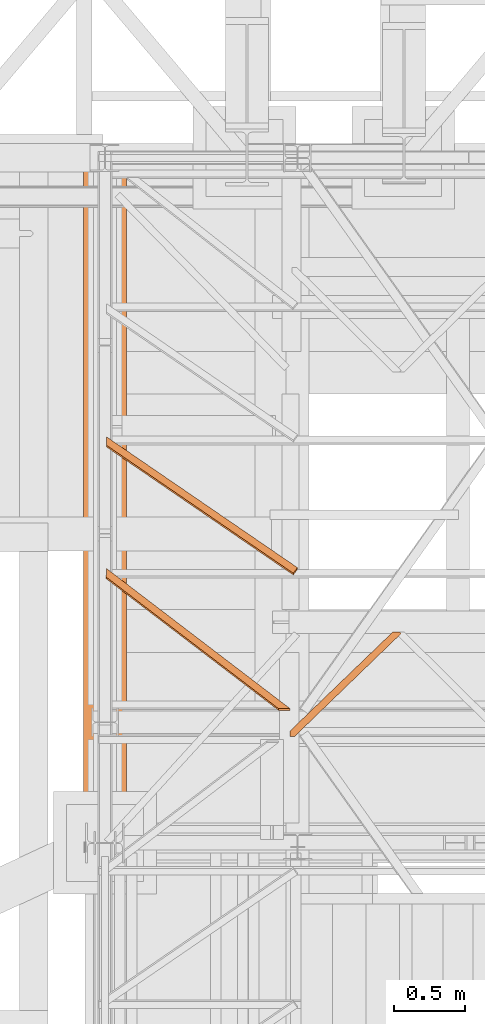
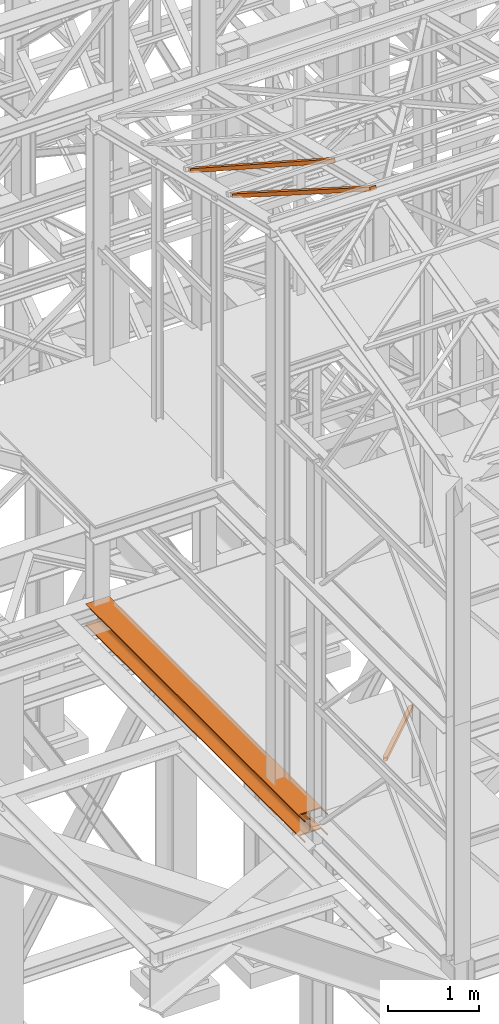
# One storey, part 27 of 208: 4 proxies.
"""IFC2X3 building model written with IfcOpenShell, lengths in millimetres."""

from ifc_helpers import new_model, entity, si_unit, converted_unit, frame, origin, origin_with_axes, place, context, subcontext, project, spatial, faceted_brep, element, save


model = new_model("IFC2X3")

# Units and contexts
model_context = context("Model", 3, precision=1e-05, world=origin())
plan_context = context("Plan", 3, precision=1e-05, world=origin())
body_context = subcontext(model_context, "Body", "Model", "MODEL_VIEW")
ifc_project = project(units=[si_unit("LENGTHUNIT", "METRE", prefix="MILLI"), converted_unit("PLANEANGLEUNIT", "DEGREE", entity("IfcPlaneAngleMeasure", 0.0174532925199433), si_unit("PLANEANGLEUNIT", "RADIAN"), dimensions=[0, 0, 0, 0, 0, 0, 0]), si_unit("AREAUNIT", "SQUARE_METRE"), si_unit("VOLUMEUNIT", "CUBIC_METRE")], contexts=[model_context, plan_context])

# Building, storey
building_placement = place(None, origin())
building = spatial("IfcBuilding", under=ifc_project, at=building_placement, CompositionType="COMPLEX")
storey_placement = place(building_placement, origin_with_axes())
storey = spatial("IfcBuildingStorey", under=building, at=storey_placement, Name="Geschoss", CompositionType="ELEMENT")

# Proxies
proxy_1_placement = place(storey_placement, frame((2493.538204317862, -21317.27439027057, 5124.989999999998), z_axis=(0.0, 0.0, 1.0), x_axis=(1.0, 0.0, 0.0)))
element("IfcBuildingElementProxy", 1, at=proxy_1_placement, inside=storey, context=body_context, shape_type="Brep", body=[
    faceted_brep([(722.7511509365713, 733.210000142677, 50.01000000000022), (0.01000000000021828, 37.12981500374735, 50.01000000000022), (0.01000000000021828, 37.12981500374735, 0.01000000000021828), (722.7511509365713, 733.210000142677, 0.01000000000021828), (722.7511509365713, 733.210000142677, 0.01000000000021828), (0.01000000000021828, 37.12981500374735, 0.01000000000021828), (0.01000000000112777, 0.00999999999839929, 0.01000000000021828), (33.18012058976092, 0.00999999999839929, 0.009999999999308784), (780.9982888236364, 722.3501135925508, 0.01000000000021828), (766.4063343387788, 733.210000142677, 0.01000000000021828), (780.9982888236364, 722.3501135925508, 0.01000000000021828), (33.18012058976092, 0.00999999999839929, 0.009999999999308784), (33.18012058976092, 0.00999999999839929, 50.00999999999931), (780.9982888236364, 722.3501135925508, 50.01000000000022), (780.9982888236364, 722.3501135925508, 50.01000000000022), (33.18012058976092, 0.00999999999839929, 50.00999999999931), (0.01000000000203727, 0.00999999999839929, 50.01000000000022), (0.01000000000021828, 37.12981500374735, 50.01000000000022), (722.7511509365713, 733.210000142677, 50.01000000000022), (766.4063343387788, 733.210000142677, 50.01000000000022), (766.4063343387788, 733.210000142677, 0.01000000000021828), (780.9982888236364, 722.3501135925508, 0.01000000000021828), (780.9982888236364, 722.3501135925508, 50.01000000000022), (766.4063343387788, 733.210000142677, 50.01000000000022), (766.4063343387788, 733.210000142677, 46.01000000000022), (777.7894357355754, 724.7382638933559, 46.01000000000022), (777.7894357355754, 724.7382638933559, 4.010000000000218), (766.4063343387788, 733.210000142677, 4.010000000000218), (728.2405771232097, 733.210000142677, 4.010000000000218), (0.01000000000203727, 31.38144639979873, 4.010000000000218), (0.01000000000203727, 31.38144639979873, 46.01000000000022), (728.2405771232097, 733.210000142677, 46.01000000000022), (766.4063343387788, 733.210000142677, 4.010000000000218), (777.7894357355754, 724.7382638933559, 4.010000000000218), (27.69069440312251, 0.00999999999839929, 4.010000000000218), (0.01000000000203727, 0.00999999999839929, 4.010000000000218), (0.01000000000203727, 31.38144639979873, 4.010000000000218), (728.2405771232097, 733.210000142677, 4.010000000000218), (777.7894357355754, 724.7382638933559, 4.010000000000218), (777.7894357355754, 724.7382638933559, 46.01000000000022), (27.69069440312251, 0.00999999999839929, 46.01000000000022), (27.69069440312251, 0.00999999999839929, 4.010000000000218), (777.7894357355754, 724.7382638933559, 46.01000000000022), (766.4063343387788, 733.210000142677, 46.01000000000022), (728.2405771232097, 733.210000142677, 46.01000000000022), (0.01000000000203727, 31.38144639979873, 46.01000000000022), (0.01000000000112777, 0.00999999999839929, 46.01000000000022), (27.69069440312251, 0.00999999999839929, 46.01000000000022), (0.01000000000203727, 0.00999999999839929, 4.010000000000218), (27.69069440312251, 0.00999999999839929, 4.010000000000218), (27.69069440312251, 0.00999999999839929, 46.01000000000022), (0.01000000000112777, 0.00999999999839929, 46.01000000000022), (0.01000000000203727, 0.00999999999839929, 50.01000000000022), (33.18012058976092, 0.00999999999839929, 50.00999999999931), (33.18012058976092, 0.00999999999839929, 0.009999999999308784), (0.01000000000112777, 0.00999999999839929, 0.01000000000021828), (0.01000000000021828, 37.12981500374735, 50.01000000000022), (0.01000000000203727, 0.00999999999839929, 50.01000000000022), (0.01000000000112777, 0.00999999999839929, 46.01000000000022), (0.01000000000203727, 31.38144639979873, 46.01000000000022), (0.01000000000203727, 31.38144639979873, 4.010000000000218), (0.01000000000203727, 0.00999999999839929, 4.010000000000218), (0.01000000000112777, 0.00999999999839929, 0.01000000000021828), (0.01000000000021828, 37.12981500374735, 0.01000000000021828), (722.7511509365713, 733.210000142677, 0.01000000000021828), (766.4063343387788, 733.210000142677, 0.01000000000021828), (766.4063343387788, 733.210000142677, 4.010000000000218), (728.2405771232097, 733.210000142677, 4.010000000000218), (728.2405771232097, 733.210000142677, 46.01000000000022), (766.4063343387788, 733.210000142677, 46.01000000000022), (766.4063343387788, 733.210000142677, 50.01000000000022), (722.7511509365713, 733.210000142677, 50.01000000000022)], [[[0, 1, 2, 3]], [[4, 5, 6, 7, 8, 9]], [[10, 11, 12, 13]], [[14, 15, 16, 17, 18, 19]], [[20, 21, 22, 23, 24, 25, 26, 27]], [[28, 29, 30, 31]], [[32, 33, 34, 35, 36, 37]], [[38, 39, 40, 41]], [[42, 43, 44, 45, 46, 47]], [[48, 49, 50, 51, 52, 53, 54, 55]], [[56, 57, 58, 59, 60, 61, 62, 63]], [[64, 65, 66, 67, 68, 69, 70, 71]]], orient=[[False], [False], [False], [False], [False], [False], [False], [False], [False], [False], [False], [False]]),
])
proxy_2_placement = place(storey_placement, frame((1209.754965757054, -20185.54963276443, 12214.24717333412), z_axis=(0.0, 0.0, 1.0), x_axis=(1.0, 0.0, 0.0)))
element("IfcBuildingElementProxy", 2, at=proxy_2_placement, inside=storey, context=body_context, shape_type="Brep", body=[
    faceted_brep([(1308.5389233782, 0.00999999999839929, 232.0521250666225), (1308.5389233782, 11.80406569683328, 280.6412186405796), (1337.349720073477, 51.51581022395476, 271.0019582749592), (1337.349720073477, 39.72174452711988, 222.4128647010039), (0.009999999999990905, 896.5242864318316, 14.44056628674844), (0.009999999999990905, 908.3183521286664, 63.02965986070558), (1308.5389233782, 11.80406569683328, 280.6412186405796), (1308.5389233782, 0.00999999999839929, 232.0521250666225), (0.009999999999990905, 955.9752131652676, 0.01000000000021828), (0.009999999999990905, 896.5242864318316, 14.44056628674844), (1308.5389233782, 0.00999999999839929, 232.0521250666225), (1337.349720073477, 39.72174452711988, 222.4128647010039), (0.009999999999990905, 967.7692788621025, 48.59909357395554), (0.009999999999990905, 955.9752131652676, 0.01000000000021828), (1337.349720073477, 39.72174452711988, 222.4128647010039), (1337.349720073477, 51.51581022395476, 271.0019582749592), (0.009999999999990905, 908.3183521286664, 63.02965986070558), (0.009999999999990905, 967.7692788621025, 48.59909357395554), (1337.349720073477, 51.51581022395476, 271.0019582749592), (1308.5389233782, 11.80406569683328, 280.6412186405796), (0.009999999999990905, 896.5242864318316, 14.44056628674844), (0.009999999999990905, 955.9752131652676, 0.01000000000021828), (0.009999999999990905, 967.7692788621025, 48.59909357395554), (0.009999999999990905, 908.3183521286664, 63.02965986070558)], [[[0, 1, 2, 3]], [[4, 5, 6, 7]], [[8, 9, 10, 11]], [[12, 13, 14, 15]], [[16, 17, 18, 19]], [[20, 21, 22, 23]]], orient=[[False], [False], [False], [False], [False], [False]]),
])
proxy_3_placement = place(storey_placement, frame((1048.164817752956, -22062.57438972183, 4994.990005364416), z_axis=(0.0, 0.0, 1.0), x_axis=(1.0, 0.0, 0.0)))
element("IfcBuildingElementProxy", 3, at=proxy_3_placement, inside=storey, context=body_context, shape_type="Brep", body=[
    faceted_brep([(300.01, 0.00999999999839929, 290.0100000000002), (300.0100000000009, 4805.080528512528, 290.0100000000002), (300.0100000000009, 4805.080528512528, 276.0100000000002), (300.01, 0.00999999999839929, 276.0100000000002), (300.01, 0.00999999999839929, 276.0100000000002), (300.0100000000009, 4805.080528512528, 276.0100000000002), (181.2600000000009, 4805.080528512528, 276.0100000000002), (181.26, 140.0099999999984, 276.0100000000002), (285.0100063934713, 140.0099999999984, 276.0100000000002), (285.0100063934713, 0.00999999999839929, 276.0100000000002), (181.26, 140.0099999999984, 276.0100000000002), (181.2600000000009, 4805.080528512528, 276.0100000000002), (172.9165694541396, 4805.080528512528, 274.6884339422595), (172.9165694541387, 140.0099999999984, 274.6884339422595), (172.9165694541387, 140.0099999999984, 274.6884339422595), (172.9165694541396, 4805.080528512528, 274.6884339422595), (165.3898249341989, 4805.080528512528, 270.8534254634033), (165.389824934198, 140.0099999999984, 270.8534254634024), (165.389824934198, 140.0099999999984, 270.8534254634024), (165.3898249341989, 4805.080528512528, 270.8534254634033), (159.4165745365979, 4805.080528512528, 264.8801750658022), (159.416574536597, 140.0099999999984, 264.8801750658022), (159.416574536597, 140.0099999999984, 264.8801750658022), (159.4165745365979, 4805.080528512528, 264.8801750658022), (155.5815660577398, 4805.080528512528, 257.3534305458616), (155.5815660577389, 140.0099999999984, 257.3534305458607), (155.5815660577389, 140.0099999999984, 257.3534305458607), (155.5815660577398, 4805.080528512528, 257.3534305458616), (154.2600000000009, 4805.080528512528, 249.0100000000002), (154.26, 140.0099999999984, 249.0100000000002), (154.26, 140.0099999999984, 249.0100000000002), (154.2600000000009, 4805.080528512528, 249.0100000000002), (154.2600000000009, 4805.080528512528, 41.01000000000022), (154.26, 140.0099999999984, 41.01000000000022), (154.26, 140.0099999999984, 41.01000000000022), (154.2600000000009, 4805.080528512528, 41.01000000000022), (155.5815660577398, 4805.080528512528, 32.6665694541407), (155.5815660577389, 140.0099999999984, 32.66656945413979), (155.5815660577389, 140.0099999999984, 32.66656945413979), (155.5815660577398, 4805.080528512528, 32.6665694541407), (159.4165745365979, 4805.080528512528, 25.13982493419917), (159.416574536597, 140.0099999999984, 25.13982493419826), (159.416574536597, 140.0099999999984, 25.13982493419826), (159.4165745365979, 4805.080528512528, 25.13982493419917), (165.3898249341989, 4805.080528512528, 19.166574536599), (165.389824934198, 140.0099999999984, 19.16657453659809), (165.389824934198, 140.0099999999984, 19.16657453659809), (165.3898249341989, 4805.080528512528, 19.166574536599), (172.9165694541396, 4805.080528512528, 15.33156605774093), (172.9165694541387, 140.0099999999984, 15.33156605774093), (172.9165694541387, 140.0099999999984, 15.33156605774093), (172.9165694541396, 4805.080528512528, 15.33156605774093), (181.2600000000009, 4805.080528512528, 14.01000000000022), (181.26, 140.0099999999984, 14.01000000000022), (181.26, 140.0099999999984, 14.01000000000022), (181.2600000000009, 4805.080528512528, 14.01000000000022), (300.0100000000009, 4805.080528512528, 14.01000000000022), (300.01, 0.00999999999839929, 14.01000000000022), (285.0100063934713, 0.00999999999839929, 14.01000000000022), (285.0100063934713, 140.0099999999984, 14.01000000000022), (300.01, 0.00999999999839929, 14.01000000000022), (300.0100000000009, 4805.080528512528, 14.01000000000022), (300.0100000000009, 4805.080528512528, 0.01000000000021828), (300.01, 0.00999999999839929, 0.01000000000021828), (300.01, 0.00999999999839929, 0.01000000000021828), (300.0100000000009, 4805.080528512528, 0.01000000000021828), (0.0100000000009004, 4805.080528512528, 0.01000000000021828), (0.009999999999990905, 0.00999999999839929, 0.01000000000021828), (15.0099956646352, 0.00999999999839929, 0.01000000000021828), (15.0099956646352, 140.0099999999984, 0.01000000000021828), (285.0100063934713, 140.0099999999984, 0.01000000000021828), (285.0100063934713, 0.00999999999839929, 0.01000000000021828), (0.009999999999990905, 0.00999999999839929, 0.01000000000021828), (0.0100000000009004, 4805.080528512528, 0.01000000000021828), (0.0100000000009004, 4805.080528512528, 14.01000000000022), (0.009999999999990905, 0.00999999999839929, 14.01000000000022), (0.009999999999990905, 0.00999999999839929, 14.01000000000022), (0.0100000000009004, 4805.080528512528, 14.01000000000022), (118.7600000000009, 4805.080528512528, 14.01000000000022), (118.76, 140.0099999999984, 14.01000000000022), (15.0099956646352, 140.0099999999984, 14.01000000000022), (15.0099956646352, 0.00999999999839929, 14.01000000000022), (118.76, 140.0099999999984, 14.01000000000022), (118.7600000000009, 4805.080528512528, 14.01000000000022), (127.1034305458604, 4805.080528512528, 15.33156605774093), (127.1034305458595, 140.0099999999984, 15.33156605774093), (127.1034305458595, 140.0099999999984, 15.33156605774093), (127.1034305458604, 4805.080528512528, 15.33156605774093), (134.630175065801, 4805.080528512528, 19.166574536599), (134.6301750658001, 140.0099999999984, 19.16657453659809), (134.6301750658001, 140.0099999999984, 19.16657453659809), (134.630175065801, 4805.080528512528, 19.166574536599), (140.6034254634021, 4805.080528512528, 25.13982493419917), (140.6034254634012, 140.0099999999984, 25.13982493419826), (140.6034254634012, 140.0099999999984, 25.13982493419826), (140.6034254634021, 4805.080528512528, 25.13982493419917), (144.4384339422602, 4805.080528512528, 32.6665694541407), (144.4384339422593, 140.0099999999984, 32.66656945413979), (144.4384339422593, 140.0099999999984, 32.66656945413979), (144.4384339422602, 4805.080528512528, 32.6665694541407), (145.7600000000009, 4805.080528512528, 41.01000000000022), (145.76, 140.0099999999984, 41.01000000000022), (145.76, 140.0099999999984, 41.01000000000022), (145.7600000000009, 4805.080528512528, 41.01000000000022), (145.7600000000009, 4805.080528512528, 249.0100000000002), (145.76, 140.0099999999984, 249.0100000000002), (145.76, 140.0099999999984, 249.0100000000002), (145.7600000000009, 4805.080528512528, 249.0100000000002), (144.4384339422602, 4805.080528512528, 257.3534305458616), (144.4384339422593, 140.0099999999984, 257.3534305458607), (144.4384339422593, 140.0099999999984, 257.3534305458607), (144.4384339422602, 4805.080528512528, 257.3534305458616), (140.6034254634021, 4805.080528512528, 264.8801750658022), (140.6034254634012, 140.0099999999984, 264.8801750658022), (140.6034254634012, 140.0099999999984, 264.8801750658022), (140.6034254634021, 4805.080528512528, 264.8801750658022), (134.630175065801, 4805.080528512528, 270.8534254634033), (134.6301750658001, 140.0099999999984, 270.8534254634024), (134.6301750658001, 140.0099999999984, 270.8534254634024), (134.630175065801, 4805.080528512528, 270.8534254634033), (127.1034305458604, 4805.080528512528, 274.6884339422595), (127.1034305458595, 140.0099999999984, 274.6884339422595), (127.1034305458595, 140.0099999999984, 274.6884339422595), (127.1034305458604, 4805.080528512528, 274.6884339422595), (118.7600000000009, 4805.080528512528, 276.0100000000002), (118.76, 140.0099999999984, 276.0100000000002), (118.76, 140.0099999999984, 276.0100000000002), (118.7600000000009, 4805.080528512528, 276.0100000000002), (0.0100000000009004, 4805.080528512528, 276.0100000000002), (0.009999999999990905, 0.00999999999839929, 276.0100000000002), (15.0099956646352, 0.00999999999839929, 276.0100000000002), (15.0099956646352, 140.0099999999984, 276.0100000000002), (0.009999999999990905, 0.00999999999839929, 276.0100000000002), (0.0100000000009004, 4805.080528512528, 276.0100000000002), (0.0100000000009004, 4805.080528512528, 290.0100000000002), (0.009999999999990905, 0.00999999999839929, 290.0100000000002), (0.009999999999990905, 0.00999999999839929, 290.0100000000002), (0.0100000000009004, 4805.080528512528, 290.0100000000002), (300.0100000000009, 4805.080528512528, 290.0100000000002), (300.01, 0.00999999999839929, 290.0100000000002), (285.0100063934704, 0.00999999999839929, 290.0100000000002), (285.0100063934704, 140.0099999999984, 290.0100000000002), (15.0099956646352, 140.0099999999984, 290.0100000000002), (15.0099956646352, 0.00999999999839929, 290.0100000000002), (300.01, 0.00999999999839929, 290.0100000000002), (300.01, 0.00999999999839929, 276.0100000000002), (285.0100063934713, 0.00999999999839929, 276.0100000000002), (285.0100063934704, 0.00999999999839929, 290.0100000000002), (15.0099956646352, 0.00999999999839929, 14.01000000000022), (15.0099956646352, 0.00999999999839929, 0.01000000000021828), (0.009999999999990905, 0.00999999999839929, 0.01000000000021828), (0.009999999999990905, 0.00999999999839929, 14.01000000000022), (15.0099956646352, 0.00999999999839929, 276.0100000000002), (0.009999999999990905, 0.00999999999839929, 276.0100000000002), (0.009999999999990905, 0.00999999999839929, 290.0100000000002), (15.0099956646352, 0.00999999999839929, 290.0100000000002), (285.0100063934713, 0.00999999999839929, 0.01000000000021828), (285.0100063934713, 0.00999999999839929, 14.01000000000022), (300.01, 0.00999999999839929, 14.01000000000022), (300.01, 0.00999999999839929, 0.01000000000021828), (300.0100000000009, 4805.080528512528, 290.0100000000002), (0.0100000000009004, 4805.080528512528, 290.0100000000002), (0.0100000000009004, 4805.080528512528, 276.0100000000002), (118.7600000000009, 4805.080528512528, 276.0100000000002), (127.1034305458604, 4805.080528512528, 274.6884339422595), (134.630175065801, 4805.080528512528, 270.8534254634033), (140.6034254634021, 4805.080528512528, 264.8801750658022), (144.4384339422602, 4805.080528512528, 257.3534305458616), (145.7600000000009, 4805.080528512528, 249.0100000000002), (145.7600000000009, 4805.080528512528, 41.01000000000022), (144.4384339422602, 4805.080528512528, 32.6665694541407), (140.6034254634021, 4805.080528512528, 25.13982493419917), (134.630175065801, 4805.080528512528, 19.166574536599), (127.1034305458604, 4805.080528512528, 15.33156605774093), (118.7600000000009, 4805.080528512528, 14.01000000000022), (0.0100000000009004, 4805.080528512528, 14.01000000000022), (0.0100000000009004, 4805.080528512528, 0.01000000000021828), (300.0100000000009, 4805.080528512528, 0.01000000000021828), (300.0100000000009, 4805.080528512528, 14.01000000000022), (181.2600000000009, 4805.080528512528, 14.01000000000022), (172.9165694541396, 4805.080528512528, 15.33156605774093), (165.3898249341989, 4805.080528512528, 19.166574536599), (159.4165745365979, 4805.080528512528, 25.13982493419917), (155.5815660577398, 4805.080528512528, 32.6665694541407), (154.2600000000009, 4805.080528512528, 41.01000000000022), (154.2600000000009, 4805.080528512528, 249.0100000000002), (155.5815660577398, 4805.080528512528, 257.3534305458616), (159.4165745365979, 4805.080528512528, 264.8801750658022), (165.3898249341989, 4805.080528512528, 270.8534254634033), (172.9165694541396, 4805.080528512528, 274.6884339422595), (181.2600000000009, 4805.080528512528, 276.0100000000002), (300.0100000000009, 4805.080528512528, 276.0100000000002), (285.0100063934704, 140.0099999999984, 290.0100000000002), (285.0100063934704, 0.00999999999839929, 290.0100000000002), (285.0100063934713, 0.00999999999839929, 276.0100000000002), (285.0100063934713, 140.0099999999984, 276.0100000000002), (285.0100063934713, 140.0099999999984, 14.01000000000022), (285.0100063934713, 0.00999999999839929, 14.01000000000022), (285.0100063934713, 0.00999999999839929, 0.01000000000021828), (285.0100063934713, 140.0099999999984, 0.01000000000021828), (285.0100063934713, 140.0099999999984, 0.01000000000021828), (15.0099956646352, 140.0099999999984, 0.01000000000021828), (15.0099956646352, 140.0099999999984, 14.01000000000022), (118.76, 140.0099999999984, 14.01000000000022), (127.1034305458595, 140.0099999999984, 15.33156605774093), (134.6301750658001, 140.0099999999984, 19.16657453659809), (140.6034254634012, 140.0099999999984, 25.13982493419826), (144.4384339422593, 140.0099999999984, 32.66656945413979), (145.76, 140.0099999999984, 41.01000000000022), (145.76, 140.0099999999984, 249.0100000000002), (144.4384339422593, 140.0099999999984, 257.3534305458607), (140.6034254634012, 140.0099999999984, 264.8801750658022), (134.6301750658001, 140.0099999999984, 270.8534254634024), (127.1034305458595, 140.0099999999984, 274.6884339422595), (118.76, 140.0099999999984, 276.0100000000002), (15.0099956646352, 140.0099999999984, 276.0100000000002), (15.0099956646352, 140.0099999999984, 290.0100000000002), (285.0100063934704, 140.0099999999984, 290.0100000000002), (285.0100063934713, 140.0099999999984, 276.0100000000002), (181.26, 140.0099999999984, 276.0100000000002), (172.9165694541387, 140.0099999999984, 274.6884339422595), (165.389824934198, 140.0099999999984, 270.8534254634024), (159.416574536597, 140.0099999999984, 264.8801750658022), (155.5815660577389, 140.0099999999984, 257.3534305458607), (154.26, 140.0099999999984, 249.0100000000002), (154.26, 140.0099999999984, 41.01000000000022), (155.5815660577389, 140.0099999999984, 32.66656945413979), (159.416574536597, 140.0099999999984, 25.13982493419826), (165.389824934198, 140.0099999999984, 19.16657453659809), (172.9165694541387, 140.0099999999984, 15.33156605774093), (181.26, 140.0099999999984, 14.01000000000022), (285.0100063934713, 140.0099999999984, 14.01000000000022), (15.0099956646352, 140.0099999999984, 0.01000000000021828), (15.0099956646352, 0.00999999999839929, 0.01000000000021828), (15.0099956646352, 0.00999999999839929, 14.01000000000022), (15.0099956646352, 140.0099999999984, 14.01000000000022), (15.0099956646352, 140.0099999999984, 276.0100000000002), (15.0099956646352, 0.00999999999839929, 276.0100000000002), (15.0099956646352, 0.00999999999839929, 290.0100000000002), (15.0099956646352, 140.0099999999984, 290.0100000000002)], [[[0, 1, 2, 3]], [[4, 5, 6, 7, 8, 9]], [[10, 11, 12, 13]], [[14, 15, 16, 17]], [[18, 19, 20, 21]], [[22, 23, 24, 25]], [[26, 27, 28, 29]], [[30, 31, 32, 33]], [[34, 35, 36, 37]], [[38, 39, 40, 41]], [[42, 43, 44, 45]], [[46, 47, 48, 49]], [[50, 51, 52, 53]], [[54, 55, 56, 57, 58, 59]], [[60, 61, 62, 63]], [[64, 65, 66, 67, 68, 69, 70, 71]], [[72, 73, 74, 75]], [[76, 77, 78, 79, 80, 81]], [[82, 83, 84, 85]], [[86, 87, 88, 89]], [[90, 91, 92, 93]], [[94, 95, 96, 97]], [[98, 99, 100, 101]], [[102, 103, 104, 105]], [[106, 107, 108, 109]], [[110, 111, 112, 113]], [[114, 115, 116, 117]], [[118, 119, 120, 121]], [[122, 123, 124, 125]], [[126, 127, 128, 129, 130, 131]], [[132, 133, 134, 135]], [[136, 137, 138, 139, 140, 141, 142, 143]], [[144, 145, 146, 147]], [[148, 149, 150, 151]], [[152, 153, 154, 155]], [[156, 157, 158, 159]], [[160, 161, 162, 163, 164, 165, 166, 167, 168, 169, 170, 171, 172, 173, 174, 175, 176, 177, 178, 179, 180, 181, 182, 183, 184, 185, 186, 187, 188, 189, 190, 191]], [[192, 193, 194, 195]], [[196, 197, 198, 199]], [[200, 201, 202, 203, 204, 205, 206, 207, 208, 209, 210, 211, 212, 213, 214, 215, 216, 217, 218, 219, 220, 221, 222, 223, 224, 225, 226, 227, 228, 229, 230, 231]], [[232, 233, 234, 235]], [[236, 237, 238, 239]]], orient=[[False], [False], [False], [False], [False], [False], [False], [False], [False], [False], [False], [False], [False], [False], [False], [False], [False], [False], [False], [False], [False], [False], [False], [False], [False], [False], [False], [False], [False], [False], [False], [False], [False], [False], [False], [False], [False], [False], [False], [False], [False], [False]]),
])
proxy_4_placement = place(storey_placement, frame((1206.573389046541, -21134.17852479551, 12438.25044331833), z_axis=(0.0, 0.0, 1.0), x_axis=(1.0, 0.0, 0.0)))
element("IfcBuildingElementProxy", 4, at=proxy_4_placement, inside=storey, context=body_context, shape_type="Brep", body=[
    faceted_brep([(0.2573532659832836, 922.3433145376184, 14.22569010463667), (0.009999999999990905, 933.9898910620541, 62.8497178236812), (1208.329715697087, 11.80375053335592, 289.8813686622107), (1208.769907749942, 0.01000000000203727, 241.2935734961557), (3.438929976495956, 981.7608679819059, 0.00999999999839929), (0.2573532659832836, 922.3433145376184, 14.22569010463667), (1208.769907749942, 0.01000000000203727, 241.2935734961557), (1289.681250922849, 0.1044186754443217, 241.682558768407), (3.191576710513573, 993.4074445063416, 48.6340277190393), (3.438929976495956, 981.7608679819059, 0.00999999999839929), (1289.681250922849, 0.1044186754443217, 241.682558768407), (1289.241058869993, 11.89816920879821, 290.2703539344566), (0.009999999999990905, 933.9898910620541, 62.8497178236812), (3.191576710513573, 993.4074445063416, 48.6340277190393), (1289.241058869993, 11.89816920879821, 290.2703539344566), (1208.329715697087, 11.80375053335592, 289.8813686622107), (0.2573532659832836, 922.3433145376184, 14.22569010463667), (3.438929976495956, 981.7608679819059, 0.00999999999839929), (3.191576710513573, 993.4074445063416, 48.6340277190393), (0.009999999999990905, 933.9898910620541, 62.8497178236812), (1208.769907749942, 0.01000000000203727, 241.2935734961557), (1208.329715697087, 11.80375053335592, 289.8813686622107), (1289.241058869993, 11.89816920879821, 290.2703539344566), (1289.681250922849, 0.1044186754443217, 241.682558768407)], [[[0, 1, 2, 3]], [[4, 5, 6, 7]], [[8, 9, 10, 11]], [[12, 13, 14, 15]], [[16, 17, 18, 19]], [[20, 21, 22, 23]]], orient=[[False], [False], [False], [False], [False], [False]]),
])

save(model, "model.ifc")
